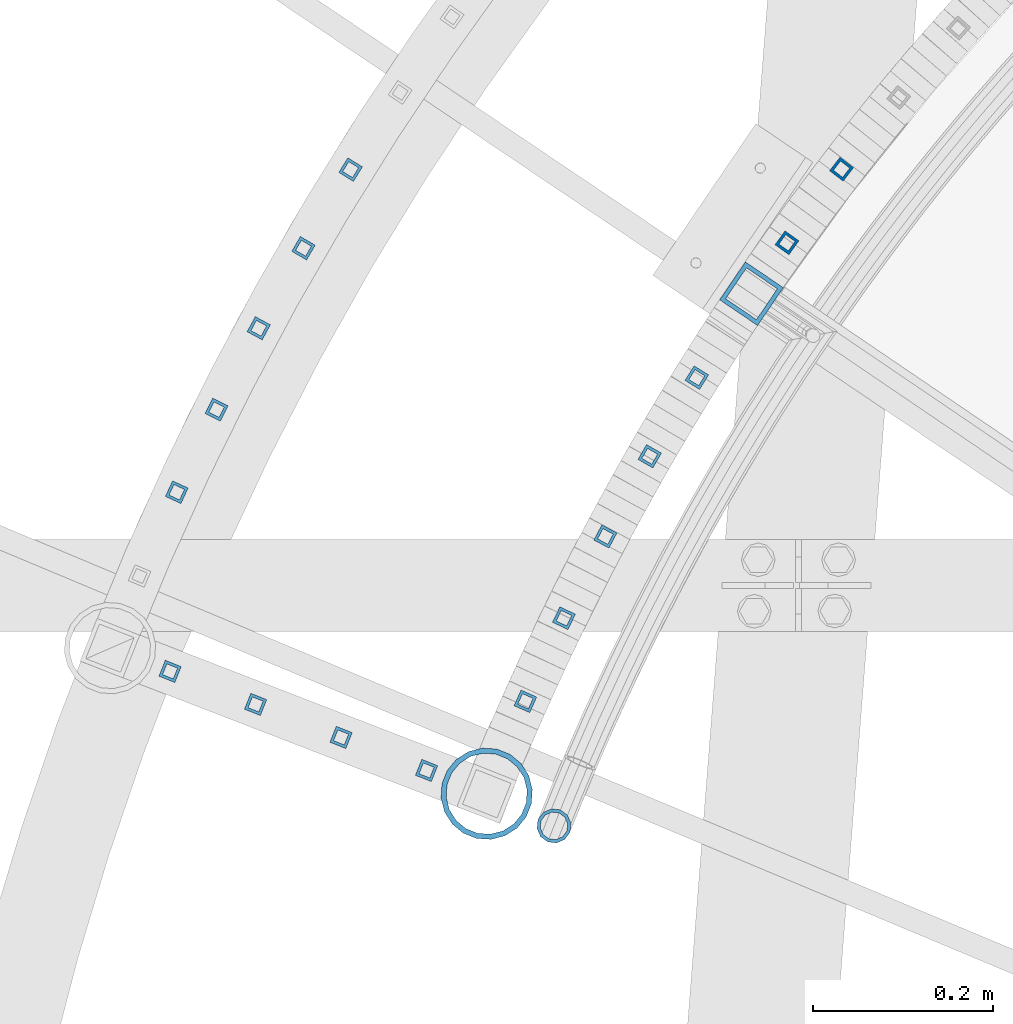
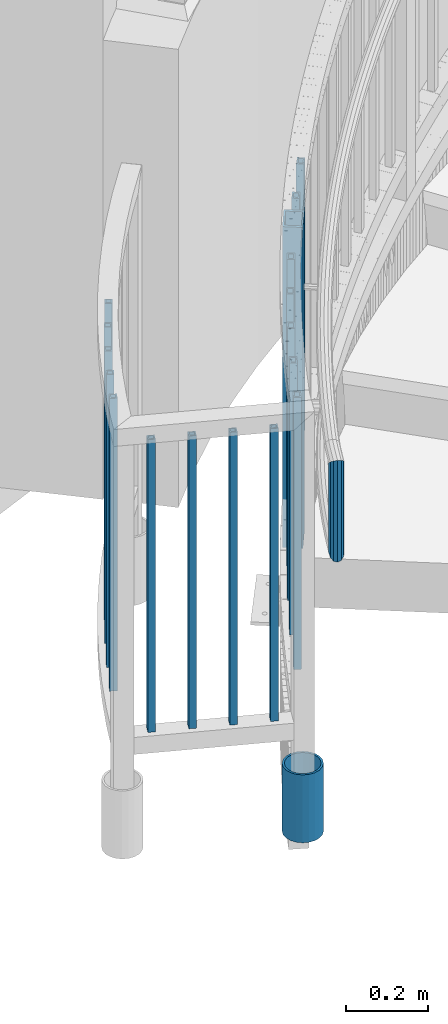
# One storey, part 261 of 975: 19 columns.
"""IFC2X3 building model written with IfcOpenShell, lengths in millimetres."""

from ifc_helpers import new_model, si_unit, frame, origin_with_axes, place, context, subcontext, project, spatial, faceted_brep, material, type_object, element, save


model = new_model("IFC2X3")

# Units and contexts
model_context = context("Model", 3, precision=1e-05, world=origin_with_axes())
body_context = subcontext(model_context, "Body", "Model", "MODEL_VIEW")
ifc_project = project(units=[si_unit("LENGTHUNIT", "METRE", prefix="MILLI"), si_unit("AREAUNIT", "SQUARE_METRE"), si_unit("VOLUMEUNIT", "CUBIC_METRE"), si_unit("MASSUNIT", "GRAM", prefix="KILO"), si_unit("TIMEUNIT", "SECOND"), si_unit("PLANEANGLEUNIT", "RADIAN"), si_unit("SOLIDANGLEUNIT", "STERADIAN"), si_unit("THERMODYNAMICTEMPERATUREUNIT", "DEGREE_CELSIUS"), si_unit("LUMINOUSINTENSITYUNIT", "LUMEN")], contexts=[model_context])

# Site, building, storey
site_placement = place(None, origin_with_axes())
site = spatial("IfcSite", under=ifc_project, at=site_placement, CompositionType="ELEMENT")
building_placement = place(site_placement, origin_with_axes())
building = spatial("IfcBuilding", under=site, at=building_placement, Name="Undefined", CompositionType="ELEMENT")
storey_placement = place(building_placement, origin_with_axes())
storey = spatial("IfcBuildingStorey", under=building, at=storey_placement, Name="Undefined", CompositionType="ELEMENT", Elevation=0.0)

# Columns
ifc_material_1 = material()
column_type_1 = type_object("IfcColumnType", Name="HSS3/4X3/4X.120_TUBES", PredefinedType="NOTDEFINED")
for number, where, z_axis, x_axis, name in (
    (1, (31999.8605543935, 4487.57716178483, 139.7), (-0.929988356103301, 0.36758897904083, 0.0), (0.0, 0.0, 1.0), "PICKET"),
    (2, (31905.0923098934, 4524.20419871634, 139.7), (-0.929988356103301, 0.36758897904083, 0.0), (0.0, 0.0, 1.0), "PICKET"),
    (3, (31810.3240653934, 4560.83123564786, 139.7), (-0.929988356103301, 0.36758897904083, 0.0), (0.0, 0.0, 1.0), "PICKET"),
):
    element("IfcColumn", number, at=place(storey_placement, frame(where, z_axis=z_axis, x_axis=x_axis)), inside=storey, type_object=column_type_1, material=ifc_material_1, Name=name, ObjectType="HSS3/4X3/4X.120_TUBES", context=body_context, shape_type="Brep", body=[
        faceted_brep([(0.0, 6.34999999998763, -6.34999999998763), (0.0, -6.35000000000582, -6.34999999998763), (876.3, -6.35000000000218, -6.3500000000131), (876.3, 6.34999999999854, -6.35000000000946), (0.0, -6.34999999998763, 6.34999999998763), (876.3, -6.34999999999854, 6.34999999999127), (0.0, 6.35000000000946, 6.34999999998763), (876.3, 6.35000000000582, 6.34999999999491), (0.0, 9.52499999997963, -9.52499999997963), (0.0, 9.52500000000873, 9.5249999999869), (876.3, 9.52500000000146, 9.52499999999418), (876.3, 9.52499999999782, -9.52500000001237), (0.0, -9.52499999997963, 9.52499999998327), (876.3, -9.52499999999782, 9.52499999999054), (0.0, -9.52500000000873, -9.5249999999869), (876.3, -9.52500000000146, -9.52500000001237)], [[[0, 1, 2, 3]], [[1, 4, 5, 2]], [[4, 6, 7, 5]], [[6, 0, 3, 7]], [[8, 9, 10, 11]], [[9, 12, 13, 10]], [[12, 14, 15, 13]], [[14, 8, 11, 15]], [[13, 15, 11, 10], [5, 7, 3, 2]], [[14, 12, 9, 8], [6, 4, 1, 0]]]),
    ])
for number, where, z_axis, x_axis, name in (
    (4, (32299.4639559624, 4923.0234117709, 294.857550170119), (-0.848384053124116, 0.529381241077447, 0.0), (0.0, 0.0, 1.0), "PICKET"),
    (5, (32247.2199505148, 4835.90094443609, 262.617691590053), (-0.866586353832808, 0.499027144903721, 0.0), (0.0, 0.0, 1.0), "PICKET"),
    (6, (32198.0917479956, 4746.98424107307, 230.292867659753), (-0.88370308616691, 0.468047920088403, 0.0), (0.0, 0.0, 1.0), "PICKET"),
    (7, (32152.1408910514, 4656.38468717894, 197.993313787286), (-0.899712807745883, 0.436482374876718, 0.0), (0.0, 0.0, 1.0), "PICKET"),
):
    element("IfcColumn", number, at=place(storey_placement, frame(where, z_axis=z_axis, x_axis=x_axis)), inside=storey, type_object=column_type_1, material=ifc_material_1, Name=name, ObjectType="HSS3/4X3/4X.120_TUBES", context=body_context, shape_type="Brep", body=[
        faceted_brep([(49.0055769945691, 6.35000000000218, -6.34999999999491), (44.9581871227797, -6.35000000000946, -6.34999999998763), (859.07694731504, -6.35000000000946, -6.34999999998763), (863.112558743084, 6.35000000000218, -6.34999999999491), (44.9581871227818, -6.35000000000218, 6.34999999999491), (859.076947315043, -6.35000000000218, 6.34999999999491), (49.0055769945712, 6.35000000000946, 6.34999999998399), (863.112558743086, 6.35000000000946, 6.34999999998399), (50.017424462516, 9.52499999999782, -9.52499999999054), (50.0174244625192, 9.52500000001237, 9.52499999998327), (864.121461600098, 9.52500000001237, 9.52499999998327), (864.121461600094, 9.52499999999782, -9.52499999999054), (43.9463396548349, -9.52499999999782, 9.52499999999054), (858.068044458032, -9.52499999999782, 9.52499999999054), (43.9463396548318, -9.52500000001237, -9.52499999998327), (858.068044458029, -9.52500000001237, -9.52499999998327)], [[[0, 1, 2, 3]], [[1, 4, 5, 2]], [[4, 6, 7, 5]], [[6, 0, 3, 7]], [[8, 9, 10, 11]], [[9, 12, 13, 10]], [[12, 14, 15, 13]], [[14, 8, 11, 15]], [[13, 15, 11, 10], [5, 7, 3, 2]], [[14, 12, 9, 8], [6, 4, 1, 0]]]),
    ])
column_1_placement = place(storey_placement, frame((32459.9235056603, 5154.1284377574, 384.405094426375), z_axis=(-0.792046882138326, 0.610460266106614, 0.0), x_axis=(0.0, 0.0, 1.0)))
element("IfcColumn", 8, at=column_1_placement, inside=storey, type_object=column_type_1, material=ifc_material_1, Name="PICKET", ObjectType="HSS3/4X3/4X.120_TUBES", context=body_context, shape_type="Brep", body=[
    faceted_brep([(48.9778304891588, 6.35000000000036, -6.34999999999854), (44.9444858438005, -6.35000000000582, -6.34999999999127), (858.946568247068, -6.35000000000582, -6.34999999999127), (863.063419332087, 6.35000000000036, -6.34999999999854), (44.9444858438051, -6.35000000000036, 6.35000000000582), (858.946568247072, -6.35000000000036, 6.35000000000582), (48.9778304891634, 6.350000000004, 6.34999999999854), (863.063419332091, 6.350000000004, 6.34999999999854), (49.9861666504976, 9.52499999999964, -9.52500000000146), (49.9861666505039, 9.52500000000691, 9.52499999999418), (864.092632103347, 9.52500000000691, 9.52499999999418), (864.09263210334, 9.52499999999964, -9.52500000000146), (43.9361496824667, -9.52500000000146, 9.52500000001601), (857.917355475819, -9.52500000000146, 9.52500000001601), (43.9361496824599, -9.52500000000691, -9.52499999997963), (857.917355475812, -9.52500000000691, -9.52499999997963)], [[[0, 1, 2, 3]], [[1, 4, 5, 2]], [[4, 6, 7, 5]], [[6, 0, 3, 7]], [[8, 9, 10, 11]], [[9, 12, 13, 10]], [[12, 14, 15, 13]], [[14, 8, 11, 15]], [[13, 15, 11, 10], [5, 7, 3, 2]], [[14, 12, 9, 8], [6, 4, 1, 0]]]),
])
for number, where, z_axis, x_axis, name in (
    (9, (31915.7003259145, 5153.64654595245, 139.7), (-0.849579829134254, 0.527460059083351, 0.0), (0.0, 0.0, 1.0), "PICKET"),
    (10, (31863.4260942085, 5066.49781499287, 139.7), (-0.865335163399432, 0.501193630231348, 0.0), (0.0, 0.0, 1.0), "PICKET"),
    (11, (31813.8453774682, 4977.78902661297, 139.7), (-0.880278679242598, 0.474457002130759, 0.0), (0.0, 0.0, 1.0), "PICKET"),
    (12, (31767.0046901363, 4887.60340348721, 139.7), (-0.894396356074169, 0.447275260037092, 0.0), (0.0, 0.0, 1.0), "PICKET"),
    (13, (31722.9479760805, 4796.02555379135, 139.7), (-0.907674949190566, 0.41967390508811, 0.0), (0.0, 0.0, 1.0), "PICKET"),
):
    element("IfcColumn", number, at=place(storey_placement, frame(where, z_axis=z_axis, x_axis=x_axis)), inside=storey, type_object=column_type_1, material=ifc_material_1, Name=name, ObjectType="HSS3/4X3/4X.120_TUBES", context=body_context, shape_type="Brep", body=[
        faceted_brep([(0.0, 6.34999999998763, -6.34999999998763), (0.0, -6.35000000000582, -6.34999999998763), (876.3, -6.35000000000218, -6.3500000000131), (876.3, 6.34999999999854, -6.35000000000946), (0.0, -6.34999999998763, 6.34999999998763), (876.3, -6.34999999999854, 6.34999999999127), (0.0, 6.35000000000946, 6.34999999998763), (876.3, 6.35000000000582, 6.34999999999491), (0.0, 9.52499999997963, -9.52499999997963), (0.0, 9.52500000000873, 9.5249999999869), (876.3, 9.52500000000146, 9.52499999999418), (876.3, 9.52499999999782, -9.52500000001237), (0.0, -9.52499999997963, 9.52499999998327), (876.3, -9.52499999999782, 9.52499999999054), (0.0, -9.52500000000873, -9.5249999999869), (876.3, -9.52500000000146, -9.52500000001237)], [[[0, 1, 2, 3]], [[1, 4, 5, 2]], [[4, 6, 7, 5]], [[6, 0, 3, 7]], [[8, 9, 10, 11]], [[9, 12, 13, 10]], [[12, 14, 15, 13]], [[14, 8, 11, 15]], [[13, 15, 11, 10], [5, 7, 3, 2]], [[14, 12, 9, 8], [6, 4, 1, 0]]]),
    ])
column_2_placement = place(storey_placement, frame((32109.4249420846, 4564.21577634898, 165.710070601664), z_axis=(-0.914595463951354, 0.404370049978491, 0.0), x_axis=(0.0, 0.0, 1.0)))
element("IfcColumn", 14, at=column_2_placement, inside=storey, type_object=column_type_1, material=ifc_material_1, Name="PICKET", ObjectType="HSS3/4X3/4X.120_TUBES", context=body_context, shape_type="Brep", body=[
    faceted_brep([(49.0055769945691, 6.35000000000218, -6.34999999999491), (44.9581871227797, -6.35000000000946, -6.34999999998763), (859.07694731504, -6.35000000000946, -6.34999999998763), (863.112558743084, 6.35000000000218, -6.34999999999491), (44.9581871227818, -6.35000000000218, 6.34999999999491), (859.076947315043, -6.35000000000218, 6.34999999999491), (49.0055769945712, 6.35000000000946, 6.34999999998399), (863.112558743086, 6.35000000000946, 6.34999999998399), (50.017424462516, 9.52499999999782, -9.52499999999054), (50.0174244625192, 9.52500000001237, 9.52499999998327), (864.121461600098, 9.52500000001237, 9.52499999998327), (864.121461600094, 9.52499999999782, -9.52499999999054), (43.9463396548349, -9.52499999999782, 9.52499999999054), (858.068044458032, -9.52499999999782, 9.52499999999054), (43.9463396548318, -9.52500000001237, -9.52499999998327), (858.068044458029, -9.52500000001237, -9.52499999998327)], [[[0, 1, 2, 3]], [[1, 4, 5, 2]], [[4, 6, 7, 5]], [[6, 0, 3, 7]], [[8, 9, 10, 11]], [[9, 12, 13, 10]], [[12, 14, 15, 13]], [[14, 8, 11, 15]], [[13, 15, 11, 10], [5, 7, 3, 2]], [[14, 12, 9, 8], [6, 4, 1, 0]]]),
])
column_3_placement = place(storey_placement, frame((31715.5558208934, 4597.45827257938, 139.7), z_axis=(-0.929988356103301, 0.36758897904083, 0.0), x_axis=(0.0, 0.0, 1.0)))
element("IfcColumn", 15, at=column_3_placement, inside=storey, type_object=column_type_1, material=ifc_material_1, Name="PICKET", ObjectType="HSS3/4X3/4X.120_TUBES", context=body_context, shape_type="Brep", body=[
    faceted_brep([(0.0, 6.34999999998763, -6.34999999998763), (0.0, -6.35000000000582, -6.34999999998763), (876.3, -6.35000000000218, -6.3500000000131), (876.3, 6.34999999999854, -6.35000000000946), (0.0, -6.34999999998763, 6.34999999998763), (876.3, -6.34999999999854, 6.34999999999127), (0.0, 6.35000000000946, 6.34999999998763), (876.3, 6.35000000000582, 6.34999999999491), (0.0, 9.52499999997963, -9.52499999997963), (0.0, 9.52500000000873, 9.5249999999869), (876.3, 9.52500000000146, 9.52499999999418), (876.3, 9.52499999999782, -9.52500000001237), (0.0, -9.52499999997963, 9.52499999998327), (876.3, -9.52499999999782, 9.52499999999054), (0.0, -9.52500000000873, -9.5249999999869), (876.3, -9.52500000000146, -9.52500000001237)], [[[0, 1, 2, 3]], [[1, 4, 5, 2]], [[4, 6, 7, 5]], [[6, 0, 3, 7]], [[8, 9, 10, 11]], [[9, 12, 13, 10]], [[12, 14, 15, 13]], [[14, 8, 11, 15]], [[13, 15, 11, 10], [5, 7, 3, 2]], [[14, 12, 9, 8], [6, 4, 1, 0]]]),
])
column_4_placement = place(storey_placement, frame((32399.4006782396, 5072.53954279784, 352.074375423215), z_axis=(-0.813153684027733, 0.58204904101985, 0.0), x_axis=(0.0, 0.0, 1.0)))
element("IfcColumn", 16, at=column_4_placement, inside=storey, type_object=column_type_1, material=ifc_material_1, Name="PICKET", ObjectType="HSS3/4X3/4X.120_TUBES", context=body_context, shape_type="Brep", body=[
    faceted_brep([(48.9778304891588, 6.35000000000036, -6.34999999999854), (44.9444858438005, -6.35000000000582, -6.34999999999127), (858.946568247068, -6.35000000000582, -6.34999999999127), (863.063419332087, 6.35000000000036, -6.34999999999854), (44.9444858438051, -6.35000000000036, 6.35000000000582), (858.946568247072, -6.35000000000036, 6.35000000000582), (48.9778304891634, 6.350000000004, 6.34999999999854), (863.063419332091, 6.350000000004, 6.34999999999854), (49.9861666504976, 9.52499999999964, -9.52500000000146), (49.9861666505039, 9.52500000000691, 9.52499999999418), (864.092632103347, 9.52500000000691, 9.52499999999418), (864.09263210334, 9.52499999999964, -9.52500000000146), (43.9361496824667, -9.52500000000146, 9.52500000001601), (857.917355475819, -9.52500000000146, 9.52500000001601), (43.9361496824599, -9.52500000000691, -9.52499999997963), (857.917355475812, -9.52500000000691, -9.52499999997963)], [[[0, 1, 2, 3]], [[1, 4, 5, 2]], [[4, 6, 7, 5]], [[6, 0, 3, 7]], [[8, 9, 10, 11]], [[9, 12, 13, 10]], [[12, 14, 15, 13]], [[14, 8, 11, 15]], [[13, 15, 11, 10], [5, 7, 3, 2]], [[14, 12, 9, 8], [6, 4, 1, 0]]]),
])
column_type_2 = type_object("IfcColumnType", Name="HSS2X2X.188_TUBES", PredefinedType="NOTDEFINED")
column_5_placement = place(storey_placement, frame((32360.050335311, 5016.06297007344, 177.8), z_axis=(-0.827276728009954, 0.561794638006759, 0.0), x_axis=(0.0, 0.0, 1.0)))
element("IfcColumn", 17, at=column_5_placement, inside=storey, type_object=column_type_2, material=ifc_material_1, Name="HANDRAIL", ObjectType="HSS2X2X.188_TUBES", context=body_context, shape_type="Brep", body=[
    faceted_brep([(59.7770034089217, 20.6374999999425, -20.6375000000444), (46.6339334019876, -20.6375000000517, -20.6375000000335), (1006.79125658838, -20.6375000000517, -20.6375000000335), (1019.96851403156, 20.6374999999425, -20.6375000000444), (46.6339334020035, -20.6374999999389, 20.637500000048), (1006.7912565884, -20.6374999999389, 20.637500000048), (59.7770034089381, 20.6375000000517, 20.6375000000335), (1019.96851403158, 20.6375000000517, 20.6375000000335), (61.2935114866432, 25.3999999999287, -25.4000000000524), (61.2935114866632, 25.4000000000633, 25.4000000000415), (1021.48896681348, 25.4000000000633, 25.4000000000415), (1021.48896681346, 25.3999999999287, -25.4000000000524), (45.1174253242825, -25.3999999999251, 25.400000000056), (1005.27080380649, -25.3999999999251, 25.400000000056), (45.1174253242625, -25.4000000000597, -25.4000000000415), (1005.27080380647, -25.4000000000597, -25.4000000000415)], [[[0, 1, 2, 3]], [[1, 4, 5, 2]], [[4, 6, 7, 5]], [[6, 0, 3, 7]], [[8, 9, 10, 11]], [[9, 12, 13, 10]], [[12, 14, 15, 13]], [[14, 8, 11, 15]], [[13, 15, 11, 10], [5, 7, 3, 2]], [[14, 12, 9, 8], [6, 4, 1, 0]]]),
])
ifc_material_2 = material(Name="STEEL/A53")
column_type_3 = type_object("IfcColumnType", Name="PIPE3-1/2STD", PredefinedType="NOTDEFINED")
column_6_placement = place(storey_placement, frame((32066.5014628547, 4461.8210760123, -203.2), z_axis=(0.396587190921094, -0.917997058817356, -8.51161559012325e-09), x_axis=(0.0, 0.0, 1.0)))
element("IfcColumn", 18, at=column_6_placement, inside=storey, type_object=column_type_3, material=ifc_material_2, ObjectType="PIPE3-1/2STD", context=body_context, shape_type="Brep", body=[
    faceted_brep([(0.0, -45.0595999999932, 1.45519152283669e-11), (0.0, -42.8542262016344, 13.924182159768), (203.199999999991, -42.8542262017145, 13.9241821598171), (203.19999999999, -45.0596000000478, 5.82076609134674e-11), (0.0, -36.45398215971, 26.4853683542424), (203.199999999993, -36.45398215981, 26.4853683542988), (0.0, -26.4853683541623, 36.45398215979), (203.199999999995, -26.4853683542788, 36.4539821598537), (0.0, -13.9241821596988, 42.8542262017108), (203.199999999998, -13.9241821598262, 42.8542262017836), (0.0, 3.63797880709171e-11, 45.0596000000514), (203.2, -9.27684595808387e-11, 45.0596000001387), (0.0, 13.9241821597716, 42.8542262017036), (203.200000000003, 13.9241821596443, 42.8542262017927), (0.0, 26.4853683542242, 36.4539821597718), (203.200000000006, 26.4853683541096, 36.4539821598701), (0.0, 36.4539821597537, 26.4853683542206), (203.200000000008, 36.4539821596554, 26.4853683543224), (0.0, 42.8542262016563, 13.9241821597425), (203.200000000009, 42.8542262015817, 13.9241821598443), (0.0, 45.0595999999932, -1.09139364212751e-11), (203.200000000009, 45.0595999999423, 8.9130480773747e-11), (0.0, 42.8542262016344, -13.9241821597643), (203.200000000008, 42.854226201609, -13.9241821596697), (0.0, 36.45398215971, -26.4853683542387), (203.200000000007, 36.4539821597045, -26.4853683541514), (0.0, 26.4853683541623, -36.4539821597864), (203.200000000004, 26.4853683541733, -36.4539821597064), (0.0, 13.9241821596988, -42.8542262017072), (203.200000000002, 13.9241821597225, -42.8542262016381), (0.0, -3.63797880709171e-11, -45.0596000000478), (203.199999999999, -9.09494701772928e-12, -45.0595999999914), (0.0, -13.9241821597716, -42.8542262016963), (203.199999999996, -13.9241821597479, -42.8542262016472), (0.0, -26.4853683542242, -36.4539821597682), (203.199999999993, -26.4853683542133, -36.4539821597227), (0.0, -36.4539821597537, -26.4853683542169), (203.199999999992, -36.4539821597609, -26.4853683541751), (0.0, -42.8542262016563, -13.9241821597352), (203.199999999991, -42.8542262016872, -13.924182159697), (0.0, -50.799999999992, 1.81898940354586e-11), (0.0, -48.3136710278013, -15.6980633142484), (203.199999999989, -48.313671027825, -15.6980633142139), (203.199999999989, -50.8000000000466, 5.63886715099216e-11), (0.0, -41.0980633142644, -29.8594908164741), (203.19999999999, -41.0980633142663, -29.8594908164414), (0.0, -29.859490816485, -41.0980633142826), (203.199999999993, -29.8594908164687, -41.0980633142426), (0.0, -15.6980633142848, -48.313671027845), (203.199999999995, -15.6980633142539, -48.313671027794), (0.0, -4.36557456851006e-11, -50.8000000000575), (203.199999999998, -7.27595761418343e-12, -50.7999999999993), (0.0, 15.6980633142011, -48.3136710278523), (203.200000000002, 15.6980633142375, -48.3136710277831), (0.0, 29.8594908164159, -41.0980633143045), (203.200000000005, 29.8594908164378, -41.0980633142226), (0.0, 41.0980633142135, -29.8594908165032), (203.200000000008, 41.0980633142171, -29.8594908164141), (0.0, 48.3136710277722, -15.6980633142775), (203.200000000009, 48.3136710277504, -15.6980633141811), (0.0, 50.799999999992, -1.45519152283669e-11), (203.20000000001, 50.7999999999411, 9.09494701772928e-11), (0.0, 48.313671027794, 15.6980633142521), (203.20000000001, 48.3136710277213, 15.6980633143594), (0.0, 41.0980633142644, 29.8594908164814), (203.200000000008, 41.0980633141626, 29.8594908165887), (0.0, 29.859490816485, 41.0980633142863), (203.200000000007, 29.8594908163632, 41.0980633143899), (0.0, 15.6980633142848, 48.3136710278486), (203.200000000004, 15.6980633141484, 48.3136710279414), (0.0, 4.00177668780088e-11, 50.8000000000611), (203.200000000001, -9.82254277914762e-11, 50.8000000001466), (0.0, -15.6980633142011, 48.3136710278559), (203.199999999997, -15.698063314343, 48.3136710279305), (0.0, -29.8594908164159, 41.0980633143081), (203.199999999994, -29.8594908165433, 41.0980633143681), (0.0, -41.0980633142171, 29.8594908165069), (203.199999999992, -41.0980633143226, 29.8594908165596), (0.0, -48.3136710277722, 15.6980633142812), (203.19999999999, -48.3136710278559, 15.6980633143285)], [[[0, 1, 2, 3]], [[1, 4, 5, 2]], [[4, 6, 7, 5]], [[6, 8, 9, 7]], [[8, 10, 11, 9]], [[10, 12, 13, 11]], [[12, 14, 15, 13]], [[14, 16, 17, 15]], [[16, 18, 19, 17]], [[18, 20, 21, 19]], [[20, 22, 23, 21]], [[22, 24, 25, 23]], [[24, 26, 27, 25]], [[26, 28, 29, 27]], [[28, 30, 31, 29]], [[30, 32, 33, 31]], [[32, 34, 35, 33]], [[34, 36, 37, 35]], [[36, 38, 39, 37]], [[38, 0, 3, 39]], [[40, 41, 42, 43]], [[41, 44, 45, 42]], [[44, 46, 47, 45]], [[46, 48, 49, 47]], [[48, 50, 51, 49]], [[50, 52, 53, 51]], [[52, 54, 55, 53]], [[54, 56, 57, 55]], [[56, 58, 59, 57]], [[58, 60, 61, 59]], [[60, 62, 63, 61]], [[62, 64, 65, 63]], [[64, 66, 67, 65]], [[66, 68, 69, 67]], [[68, 70, 71, 69]], [[70, 72, 73, 71]], [[72, 74, 75, 73]], [[74, 76, 77, 75]], [[76, 78, 79, 77]], [[78, 40, 43, 79]], [[45, 47, 49, 51, 53, 55, 57, 59, 61, 63, 65, 67, 69, 71, 73, 75, 77, 79, 43, 42], [5, 7, 9, 11, 13, 15, 17, 19, 21, 23, 25, 27, 29, 31, 33, 35, 37, 39, 3, 2]], [[78, 76, 74, 72, 70, 68, 66, 64, 62, 60, 58, 56, 54, 52, 50, 48, 46, 44, 41, 40], [38, 36, 34, 32, 30, 28, 26, 24, 22, 20, 18, 16, 14, 12, 10, 8, 6, 4, 1, 0]]]),
])
column_type_4 = type_object("IfcColumnType", PredefinedType="NOTDEFINED")
column_7_placement = place(storey_placement, frame((32141.1094349562, 4426.18536876088, 609.6), z_axis=(0.360452691961418, 0.932777495900157, 0.0), x_axis=(0.0, 0.0, 1.0)))
element("IfcColumn", 19, at=column_7_placement, inside=storey, type_object=column_type_4, material=ifc_material_1, Name="HANDRAIL", context=body_context, shape_type="Brep", body=[
    faceted_brep([(18.9403880155145, -15.3670000000275, -5.45696821063757e-12), (26.6385732294135, -13.3082123799722, 7.68349999999555), (278.160944471276, -13.3082123799722, 7.68349999999555), (285.859055086315, -15.3670000000275, -5.45696821063757e-12), (32.3034063710468, -7.68349999999919, 13.3082123799577), (272.496315160365, -7.68349999999919, 13.3082123799577), (34.4169999991835, 4.00177668780088e-11, 15.3670000000093), (270.383000000335, 4.00177668780088e-11, 15.3670000000093), (32.4130183415748, 7.68350000002465, 13.308212379965), (272.387260088573, 7.68350000002465, 13.308212379965), (26.8284267314857, 13.3082123799868, 7.6835000000101), (277.972055546109, 13.3082123799868, 7.6835000000101), (19.1596119565705, 15.3670000000275, 7.27595761418343e-12), (285.640944942731, 15.3670000000275, 7.27595761418343e-12), (11.4614267426715, 13.3082123799722, -7.68349999999555), (293.33905555777, 13.3082123799722, -7.68349999999555), (5.79659360103824, 7.68349999999919, -13.3082123799559), (299.003684868681, 7.68349999999919, -13.3082123799559), (3.68299999994588, -2.5465851649642e-11, -15.3670000000075), (301.117000003096, -2.5465851649642e-11, -15.3670000000075), (5.68698163051022, -7.68350000002465, -13.308212379965), (299.112739940473, -7.68350000002465, -13.308212379965), (11.2715732405993, -13.3082123799868, -7.6835000000101), (293.527944482937, -13.3082123799868, -7.6835000000101), (18.91411737795, -19.050000000032, -7.27595761418343e-12), (9.40732220243524, -16.4977839421335, -9.52500000001237), (295.392079934044, -16.4977839421335, -9.52500000001237), (285.885192252282, -19.050000000032, -7.27595761418343e-12), (2.48427475191158, -9.52500000003783, -16.4977839421044), (302.315380088015, -9.52500000003783, -16.4977839421044), (-3.63797880709171e-12, 3.63797880709171e-12, -19.0500000000002), (304.800000003427, -4.00177668780088e-11, -19.0500000000102), (2.6201573600041, 9.52500000000146, -16.4977839420953), (302.180187850256, 9.52500000000146, -16.4977839420953), (9.64267778351643, 16.4977839421117, -9.52499999999418), (295.157920109457, 16.4977839421117, -9.52499999999418), (19.185882594135, 19.050000000032, 9.09494701772928e-12), (285.614807776764, 19.050000000032, 9.09494701772928e-12), (28.6926777696498, 16.4977839421335, 9.52500000001237), (276.107920095002, 16.4977839421335, 9.52500000001237), (35.6157252201734, 9.5250000000342, 16.4977839421044), (269.184619941031, 9.5250000000342, 16.4977839421044), (38.0999999990921, 5.45696821063757e-11, 19.050000000012), (266.700000000004, 5.45696821063757e-11, 19.050000000012), (35.4798426120808, -9.52500000000146, 16.4977839420972), (269.31981217879, -9.52500000000146, 16.4977839420972), (28.4573221885685, -16.4977839421117, 9.524999999996), (276.342079919589, -16.4977839421117, 9.524999999996)], [[[0, 1, 2, 3]], [[1, 4, 5, 2]], [[4, 6, 7, 5]], [[6, 8, 9, 7]], [[8, 10, 11, 9]], [[10, 12, 13, 11]], [[12, 14, 15, 13]], [[14, 16, 17, 15]], [[16, 18, 19, 17]], [[18, 20, 21, 19]], [[20, 22, 23, 21]], [[22, 0, 3, 23]], [[24, 25, 26, 27]], [[25, 28, 29, 26]], [[28, 30, 31, 29]], [[30, 32, 33, 31]], [[32, 34, 35, 33]], [[34, 36, 37, 35]], [[36, 38, 39, 37]], [[38, 40, 41, 39]], [[40, 42, 43, 41]], [[42, 44, 45, 43]], [[44, 46, 47, 45]], [[46, 24, 27, 47]], [[29, 31, 33, 35, 37, 39, 41, 43, 45, 47, 27, 26], [5, 7, 9, 11, 13, 15, 17, 19, 21, 23, 3, 2]], [[46, 44, 42, 40, 38, 36, 34, 32, 30, 28, 25, 24], [22, 20, 18, 16, 14, 12, 10, 8, 6, 4, 1, 0]]]),
])

save(model, "model.ifc")
